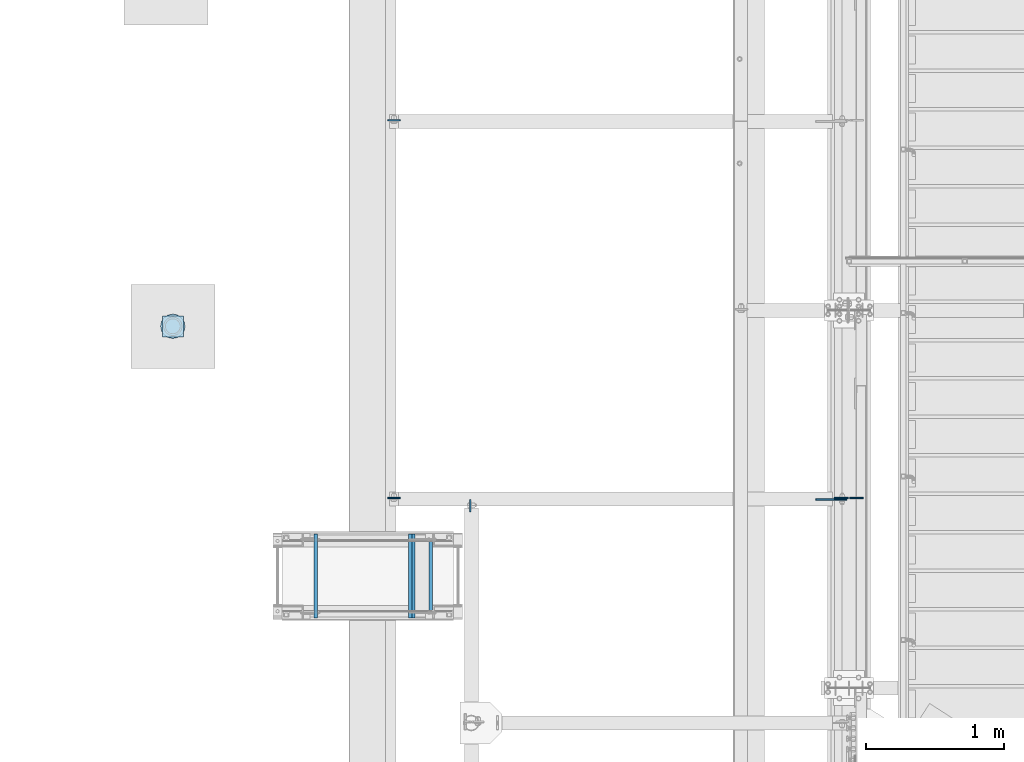
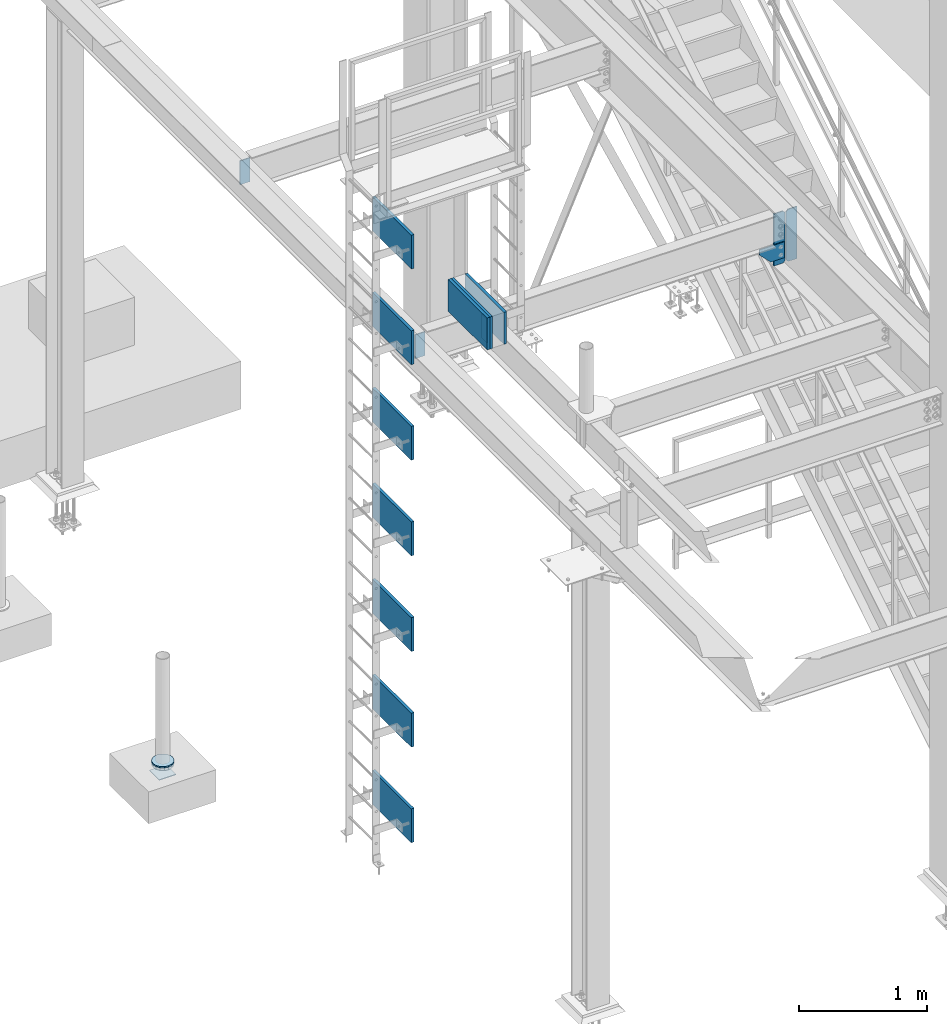
# One storey, part 3022 of 3843: 19 plates, 15 elements without a shape of their own.
"""IFC2X3 building model written with IfcOpenShell, lengths in millimetres."""

from ifc_helpers import new_model, si_unit, frame, origin_with_axes, place, context, subcontext, project, spatial, faceted_brep, material, type_object, element, aggregate, save


model = new_model("IFC2X3")

# Units and contexts
model_context = context("Model", 3, precision=1e-05, world=origin_with_axes())
body_context = subcontext(model_context, "Body", "Model", "MODEL_VIEW")
ifc_project = project(units=[si_unit("LENGTHUNIT", "METRE", prefix="MILLI"), si_unit("AREAUNIT", "SQUARE_METRE"), si_unit("VOLUMEUNIT", "CUBIC_METRE"), si_unit("MASSUNIT", "GRAM", prefix="KILO"), si_unit("TIMEUNIT", "SECOND"), si_unit("PLANEANGLEUNIT", "RADIAN"), si_unit("SOLIDANGLEUNIT", "STERADIAN"), si_unit("THERMODYNAMICTEMPERATUREUNIT", "DEGREE_CELSIUS"), si_unit("LUMINOUSINTENSITYUNIT", "LUMEN")], contexts=[model_context])

# Site, building, storey
site_placement = place(None, origin_with_axes())
site = spatial("IfcSite", under=ifc_project, at=site_placement, CompositionType="ELEMENT")
building_placement = place(site_placement, origin_with_axes())
building = spatial("IfcBuilding", under=site, at=building_placement, Name="Undefined", CompositionType="ELEMENT")
storey_placement = place(building_placement, origin_with_axes())
storey = spatial("IfcBuildingStorey", under=building, at=storey_placement, Name="Undefined", CompositionType="ELEMENT", Elevation=0.0)

# Assembly, plate
assembly_1_placement = place(storey_placement, origin_with_axes())
assembly_1 = element("IfcElementAssembly", 1, at=assembly_1_placement, inside=storey, Name="PLATE", AssemblyPlace="NOTDEFINED", PredefinedType="RIGID_FRAME")
ifc_material_1 = material(Name="STEEL/A572-50")
plate_type_1 = type_object("IfcPlateType", PredefinedType="NOTDEFINED")
plate_1_placement = place(assembly_1_placement, frame((31589.1001493349, 29690.6733759337, 30375.225), z_axis=(1.0, 0.0, 0.0), x_axis=(0.0, -1.0, 0.0)))
plate_1 = element("IfcPlate", 2, at=plate_1_placement, type_object=plate_type_1, material=ifc_material_1, Name="PLATE", context=body_context, shape_type="Brep", body=[
    faceted_brep([(0.0, -3.17499999999927, 0.0), (0.0, -3.17499999999927, 152.326975998483), (0.0, 3.17499999999927, 152.326975998483), (0.0, 3.17499999999927, 0.0), (152.326976003387, -3.17499999999927, 152.326975998483), (152.326976003387, 3.17499999999927, 152.326975998483), (152.326976003387, -3.17499999999927, 0.0), (152.326976003387, 3.17499999999927, 0.0)], [[[0, 1, 2, 3]], [[1, 4, 5, 2]], [[4, 6, 7, 5]], [[6, 0, 3, 7]], [[5, 7, 3, 2]], [[6, 4, 1, 0]]]),
])

assembly_2_placement = place(storey_placement, origin_with_axes())
assembly_2 = element("IfcElementAssembly", 3, at=assembly_2_placement, inside=storey, Name="PIPE_BOLLARD", AssemblyPlace="NOTDEFINED", PredefinedType="RIGID_FRAME")
plate_type_2 = type_object("IfcPlateType", PredefinedType="NOTDEFINED")
plate_2_placement = place(assembly_2_placement, frame((31576.3636373341, 29703.4098879337, 30486.35), z_axis=(1.0, 0.0, 0.0), x_axis=(0.0, -1.0, 0.0)))
plate_2 = element("IfcPlate", 4, at=plate_2_placement, type_object=plate_type_2, material=ifc_material_1, Name="PLATE", context=body_context, shape_type="Brep", body=[
    faceted_brep([(0.0, -6.34999999999854, 88.9000015258789), (6.76710967589679, -6.34999999999854, 122.920556195299), (6.76710967589679, 6.34999999999854, 122.920556195299), (0.0, 6.34999999999854, 88.9000015258789), (26.0382075994357, -6.34999999999854, 151.761792400561), (26.0382075994357, 6.34999999999854, 151.761792400561), (54.8794438046934, -6.34999999999854, 171.032890324102), (54.8794438046934, 6.34999999999854, 171.032890324102), (88.8999984741095, -6.34999999999854, 177.800000000003), (88.8999984741095, 6.34999999999854, 177.800000000003), (122.920556195295, -6.34999999999854, 171.032890324102), (122.920556195295, 6.34999999999854, 171.032890324102), (151.761792400553, -6.34999999999854, 151.761792400561), (151.761792400553, 6.34999999999854, 151.761792400561), (171.032890324092, -6.34999999999854, 122.920556195299), (171.032890324092, 6.34999999999854, 122.920556195299), (177.799999999988, -6.34999999999854, 88.9000015258789), (177.799999999988, 6.34999999999854, 88.9000015258789), (171.032890324091, -6.34999999999854, 54.8794438046898), (171.032890324091, 6.34999999999854, 54.8794438046898), (151.761792400553, -6.34999999999854, 26.0382075994421), (151.761792400553, 6.34999999999854, 26.0382075994421), (122.920556195295, -6.34999999999854, 6.76710967590043), (122.920556195295, 6.34999999999854, 6.76710967590043), (88.9000015258789, -6.34999999999854, 0.0), (88.9000015258789, 6.34999999999854, 0.0), (54.8794438046934, -6.34999999999854, 6.76710967590043), (54.8794438046934, 6.34999999999854, 6.76710967590043), (26.0382075994357, -6.34999999999854, 26.0382075994421), (26.0382075994357, 6.34999999999854, 26.0382075994421), (6.76710967589679, -6.34999999999854, 54.8794438046898), (6.76710967589679, 6.34999999999854, 54.8794438046898)], [[[0, 1, 2, 3]], [[1, 4, 5, 2]], [[4, 6, 7, 5]], [[6, 8, 9, 7]], [[8, 10, 11, 9]], [[10, 12, 13, 11]], [[12, 14, 15, 13]], [[14, 16, 17, 15]], [[16, 18, 19, 17]], [[18, 20, 21, 19]], [[20, 22, 23, 21]], [[22, 24, 25, 23]], [[24, 26, 27, 25]], [[26, 28, 29, 27]], [[28, 30, 31, 29]], [[30, 0, 3, 31]], [[5, 7, 9, 11, 13, 15, 17, 19, 21, 23, 25, 27, 29, 31, 3, 2]], [[30, 28, 26, 24, 22, 20, 18, 16, 14, 12, 10, 8, 6, 4, 1, 0]]]),
])
aggregate(assembly_2, [plate_2])

# Plate
plate_type_3 = type_object("IfcPlateType", PredefinedType="NOTDEFINED")
plate_3_placement = place(assembly_1_placement, frame((31576.3636373341, 29703.4098879337, 30467.3), z_axis=(1.0, 0.0, 0.0), x_axis=(0.0, -1.0, 0.0)))
plate_3 = element("IfcPlate", 5, at=plate_3_placement, type_object=plate_type_3, material=ifc_material_1, Name="PLATE", context=body_context, shape_type="Brep", body=[
    faceted_brep([(0.0, -12.7000000000007, 88.9000015258789), (6.76710967589679, -12.7000000000007, 122.920556195299), (6.76710967589679, 12.7000000000007, 122.920556195299), (0.0, 12.7000000000007, 88.9000015258789), (26.0382075994357, -12.7000000000007, 151.761792400561), (26.0382075994357, 12.7000000000007, 151.761792400561), (54.8794438046934, -12.7000000000007, 171.032890324102), (54.8794438046934, 12.7000000000007, 171.032890324102), (88.8999984741095, -12.7000000000007, 177.800000000003), (88.8999984741095, 12.7000000000007, 177.800000000003), (122.920556195295, -12.7000000000007, 171.032890324102), (122.920556195295, 12.7000000000007, 171.032890324102), (151.761792400553, -12.7000000000007, 151.761792400561), (151.761792400553, 12.7000000000007, 151.761792400561), (171.032890324092, -12.7000000000007, 122.920556195299), (171.032890324092, 12.7000000000007, 122.920556195299), (177.799999999988, -12.7000000000007, 88.9000015258789), (177.799999999988, 12.7000000000007, 88.9000015258789), (171.032890324091, -12.7000000000007, 54.8794438046898), (171.032890324091, 12.7000000000007, 54.8794438046898), (151.761792400553, -12.7000000000007, 26.0382075994421), (151.761792400553, 12.7000000000007, 26.0382075994421), (122.920556195295, -12.7000000000007, 6.76710967590043), (122.920556195295, 12.7000000000007, 6.76710967590043), (88.9000015258789, -12.7000000000007, 0.0), (88.9000015258789, 12.7000000000007, 0.0), (54.8794438046934, -12.7000000000007, 6.76710967590043), (54.8794438046934, 12.7000000000007, 6.76710967590043), (26.0382075994357, -12.7000000000007, 26.0382075994421), (26.0382075994357, 12.7000000000007, 26.0382075994421), (6.76710967589679, -12.7000000000007, 54.8794438046898), (6.76710967589679, 12.7000000000007, 54.8794438046898)], [[[0, 1, 2, 3]], [[1, 4, 5, 2]], [[4, 6, 7, 5]], [[6, 8, 9, 7]], [[8, 10, 11, 9]], [[10, 12, 13, 11]], [[12, 14, 15, 13]], [[14, 16, 17, 15]], [[16, 18, 19, 17]], [[18, 20, 21, 19]], [[20, 22, 23, 21]], [[22, 24, 25, 23]], [[24, 26, 27, 25]], [[26, 28, 29, 27]], [[28, 30, 31, 29]], [[30, 0, 3, 31]], [[5, 7, 9, 11, 13, 15, 17, 19, 21, 23, 25, 27, 29, 31, 3, 2]], [[30, 28, 26, 24, 22, 20, 18, 16, 14, 12, 10, 8, 6, 4, 1, 0]]]),
])

aggregate(assembly_1, [plate_1, plate_3])

# Assembly, plate
assembly_3_placement = place(storey_placement, origin_with_axes())
assembly_3 = element("IfcElementAssembly", 6, at=assembly_3_placement, inside=storey, Name="PLYWOOD", AssemblyPlace="NOTDEFINED", PredefinedType="NOTDEFINED")
ifc_material_2 = material(Name="TIMBER/PLYWOOD")
plate_type_4 = type_object("IfcPlateType", PredefinedType="NOTDEFINED")
plate_4_placement = place(assembly_3_placement, frame((33400.5253801807, 27800.3002775066, 35407.6158807054), z_axis=(1.72100001509535e-06, 0.0, -0.999999999998519), x_axis=(-0.999999999998519, 0.0, -1.72100001467194e-06)))
plate_4 = element("IfcPlate", 7, at=plate_4_placement, type_object=plate_type_4, material=ifc_material_2, Name="PLYWOOD", context=body_context, shape_type="Brep", body=[
    faceted_brep([(0.0, -304.799999999999, 0.0), (-3.17594676744193e-05, -304.799999999999, 305.395313003275), (-3.17594676744193e-05, 304.799999999999, 305.395313003275), (0.0, 304.799999999999, 0.0), (25.3999682407812, -304.799999999999, 305.395313003195), (25.3999682407812, 304.799999999999, 305.395313003195), (25.4000000002561, -304.799999999999, -8.00355337560177e-11), (25.4000000002561, 304.799999999999, -8.00355337560177e-11)], [[[0, 1, 2, 3]], [[1, 4, 5, 2]], [[4, 6, 7, 5]], [[6, 0, 3, 7]], [[5, 7, 3, 2]], [[6, 4, 1, 0]]]),
])
aggregate(assembly_3, [plate_4])

assembly_4_placement = place(storey_placement, origin_with_axes())
assembly_4 = element("IfcElementAssembly", 8, at=assembly_4_placement, inside=storey, Name="PLYWOOD", AssemblyPlace="NOTDEFINED", PredefinedType="NOTDEFINED")
plate_5_placement = place(assembly_4_placement, frame((33425.9253801807, 27800.3002775066, 35407.6158807054), z_axis=(1.72100001509535e-06, 0.0, -0.999999999998519), x_axis=(-0.999999999998519, 0.0, -1.72100001467194e-06)))
plate_5 = element("IfcPlate", 9, at=plate_5_placement, type_object=plate_type_4, material=ifc_material_2, Name="PLYWOOD", context=body_context, shape_type="Brep", body=[
    faceted_brep([(0.0, -304.799999999999, 0.0), (-3.17594676744193e-05, -304.799999999999, 305.395313003275), (-3.17594676744193e-05, 304.799999999999, 305.395313003275), (0.0, 304.799999999999, 0.0), (25.3999682407812, -304.799999999999, 305.395313003195), (25.3999682407812, 304.799999999999, 305.395313003195), (25.4000000002561, -304.799999999999, -8.00355337560177e-11), (25.4000000002561, 304.799999999999, -8.00355337560177e-11)], [[[0, 1, 2, 3]], [[1, 4, 5, 2]], [[4, 6, 7, 5]], [[6, 0, 3, 7]], [[5, 7, 3, 2]], [[6, 4, 1, 0]]]),
])
aggregate(assembly_4, [plate_5])

assembly_5_placement = place(storey_placement, origin_with_axes())
assembly_5 = element("IfcElementAssembly", 10, at=assembly_5_placement, inside=storey, Name="PLYWOOD", AssemblyPlace="NOTDEFINED", PredefinedType="NOTDEFINED")
plate_6_placement = place(assembly_5_placement, frame((33552.9253801807, 27800.3002775066, 35407.6158807054), z_axis=(1.72100001509535e-06, 0.0, -0.999999999998519), x_axis=(-0.999999999998519, 0.0, -1.72100001467194e-06)))
plate_6 = element("IfcPlate", 11, at=plate_6_placement, type_object=plate_type_4, material=ifc_material_2, Name="PLYWOOD", context=body_context, shape_type="Brep", body=[
    faceted_brep([(0.0, -304.799999999999, 0.0), (-3.17594676744193e-05, -304.799999999999, 305.395313003275), (-3.17594676744193e-05, 304.799999999999, 305.395313003275), (0.0, 304.799999999999, 0.0), (25.3999682407812, -304.799999999999, 305.395313003195), (25.3999682407812, 304.799999999999, 305.395313003195), (25.4000000002561, -304.799999999999, -8.00355337560177e-11), (25.4000000002561, 304.799999999999, -8.00355337560177e-11)], [[[0, 1, 2, 3]], [[1, 4, 5, 2]], [[4, 6, 7, 5]], [[6, 0, 3, 7]], [[5, 7, 3, 2]], [[6, 4, 1, 0]]]),
])
aggregate(assembly_5, [plate_6])

assembly_6_placement = place(storey_placement, origin_with_axes())
assembly_6 = element("IfcElementAssembly", 12, at=assembly_6_placement, inside=storey, Name="PLYWOOD", AssemblyPlace="NOTDEFINED", PredefinedType="NOTDEFINED")
plate_7_placement = place(assembly_6_placement, frame((32714.7253801807, 27800.3002775066, 36439.0940057054), z_axis=(1.72100001509535e-06, 0.0, -0.999999999998519), x_axis=(-0.999999999998519, 0.0, -1.72100001467194e-06)))
plate_7 = element("IfcPlate", 13, at=plate_7_placement, type_object=plate_type_4, material=ifc_material_2, Name="PLYWOOD", context=body_context, shape_type="Brep", body=[
    faceted_brep([(0.0, -304.799999999999, 0.0), (0.0, -304.800000000003, 323.849999999999), (0.0, 304.800000000003, 323.849999999999), (0.0, 304.799999999999, 0.0), (25.3999999999942, -304.800000000003, 323.849999999999), (25.3999999999942, 304.800000000003, 323.849999999999), (25.4000000002561, -304.799999999999, -8.00355337560177e-11), (25.4000000002561, 304.799999999999, -8.00355337560177e-11)], [[[0, 1, 2, 3]], [[1, 4, 5, 2]], [[4, 6, 7, 5]], [[6, 0, 3, 7]], [[5, 7, 3, 2]], [[6, 4, 1, 0]]]),
])
aggregate(assembly_6, [plate_7])

assembly_7_placement = place(storey_placement, origin_with_axes())
assembly_7 = element("IfcElementAssembly", 14, at=assembly_7_placement, inside=storey, Name="PLYWOOD", AssemblyPlace="NOTDEFINED", PredefinedType="NOTDEFINED")
plate_8_placement = place(assembly_7_placement, frame((32714.7253801807, 27800.3002775066, 35524.6940057054), z_axis=(1.72100001509535e-06, 0.0, -0.999999999998519), x_axis=(-0.999999999998519, 0.0, -1.72100001467194e-06)))
plate_8 = element("IfcPlate", 15, at=plate_8_placement, type_object=plate_type_4, material=ifc_material_2, Name="PLYWOOD", context=body_context, shape_type="Brep", body=[
    faceted_brep([(0.0, -304.799999999999, 0.0), (0.0, -304.800000000003, 323.849999999999), (0.0, 304.800000000003, 323.849999999999), (0.0, 304.799999999999, 0.0), (25.3999999999942, -304.800000000003, 323.849999999999), (25.3999999999942, 304.800000000003, 323.849999999999), (25.4000000002561, -304.799999999999, -8.00355337560177e-11), (25.4000000002561, 304.799999999999, -8.00355337560177e-11)], [[[0, 1, 2, 3]], [[1, 4, 5, 2]], [[4, 6, 7, 5]], [[6, 0, 3, 7]], [[5, 7, 3, 2]], [[6, 4, 1, 0]]]),
])
aggregate(assembly_7, [plate_8])

assembly_8_placement = place(storey_placement, origin_with_axes())
assembly_8 = element("IfcElementAssembly", 16, at=assembly_8_placement, inside=storey, Name="PLYWOOD", AssemblyPlace="NOTDEFINED", PredefinedType="NOTDEFINED")
plate_9_placement = place(assembly_8_placement, frame((32714.7253801807, 27800.3002775066, 34610.2940057054), z_axis=(1.72100001509535e-06, 0.0, -0.999999999998519), x_axis=(-0.999999999998519, 0.0, -1.72100001467194e-06)))
plate_9 = element("IfcPlate", 17, at=plate_9_placement, type_object=plate_type_4, material=ifc_material_2, Name="PLYWOOD", context=body_context, shape_type="Brep", body=[
    faceted_brep([(0.0, -304.799999999999, 0.0), (0.0, -304.800000000003, 323.849999999999), (0.0, 304.800000000003, 323.849999999999), (0.0, 304.799999999999, 0.0), (25.3999999999942, -304.800000000003, 323.849999999999), (25.3999999999942, 304.800000000003, 323.849999999999), (25.4000000002561, -304.799999999999, -8.00355337560177e-11), (25.4000000002561, 304.799999999999, -8.00355337560177e-11)], [[[0, 1, 2, 3]], [[1, 4, 5, 2]], [[4, 6, 7, 5]], [[6, 0, 3, 7]], [[5, 7, 3, 2]], [[6, 4, 1, 0]]]),
])
aggregate(assembly_8, [plate_9])

assembly_9_placement = place(storey_placement, origin_with_axes())
assembly_9 = element("IfcElementAssembly", 18, at=assembly_9_placement, inside=storey, Name="PLYWOOD", AssemblyPlace="NOTDEFINED", PredefinedType="NOTDEFINED")
plate_10_placement = place(assembly_9_placement, frame((32714.7253801807, 27800.3002775066, 33695.8940057054), z_axis=(1.72100001509535e-06, 0.0, -0.999999999998519), x_axis=(-0.999999999998519, 0.0, -1.72100001467194e-06)))
plate_10 = element("IfcPlate", 19, at=plate_10_placement, type_object=plate_type_4, material=ifc_material_2, Name="PLYWOOD", context=body_context, shape_type="Brep", body=[
    faceted_brep([(0.0, -304.799999999999, 0.0), (0.0, -304.800000000003, 323.849999999999), (0.0, 304.800000000003, 323.849999999999), (0.0, 304.799999999999, 0.0), (25.3999999999942, -304.800000000003, 323.849999999999), (25.3999999999942, 304.800000000003, 323.849999999999), (25.4000000002561, -304.799999999999, -8.00355337560177e-11), (25.4000000002561, 304.799999999999, -8.00355337560177e-11)], [[[0, 1, 2, 3]], [[1, 4, 5, 2]], [[4, 6, 7, 5]], [[6, 0, 3, 7]], [[5, 7, 3, 2]], [[6, 4, 1, 0]]]),
])
aggregate(assembly_9, [plate_10])

assembly_10_placement = place(storey_placement, origin_with_axes())
assembly_10 = element("IfcElementAssembly", 20, at=assembly_10_placement, inside=storey, Name="PLYWOOD", AssemblyPlace="NOTDEFINED", PredefinedType="NOTDEFINED")
plate_11_placement = place(assembly_10_placement, frame((32714.7253801807, 27800.3002775066, 32781.4940057054), z_axis=(1.72100001509535e-06, 0.0, -0.999999999998519), x_axis=(-0.999999999998519, 0.0, -1.72100001467194e-06)))
plate_11 = element("IfcPlate", 21, at=plate_11_placement, type_object=plate_type_4, material=ifc_material_2, Name="PLYWOOD", context=body_context, shape_type="Brep", body=[
    faceted_brep([(0.0, -304.799999999999, 0.0), (0.0, -304.800000000003, 323.849999999999), (0.0, 304.800000000003, 323.849999999999), (0.0, 304.799999999999, 0.0), (25.3999999999942, -304.800000000003, 323.849999999999), (25.3999999999942, 304.800000000003, 323.849999999999), (25.4000000002561, -304.799999999999, -8.00355337560177e-11), (25.4000000002561, 304.799999999999, -8.00355337560177e-11)], [[[0, 1, 2, 3]], [[1, 4, 5, 2]], [[4, 6, 7, 5]], [[6, 0, 3, 7]], [[5, 7, 3, 2]], [[6, 4, 1, 0]]]),
])
aggregate(assembly_10, [plate_11])

assembly_11_placement = place(storey_placement, origin_with_axes())
assembly_11 = element("IfcElementAssembly", 22, at=assembly_11_placement, inside=storey, Name="PLYWOOD", AssemblyPlace="NOTDEFINED", PredefinedType="NOTDEFINED")
plate_12_placement = place(assembly_11_placement, frame((32714.7253801807, 27800.3002775066, 31867.0940057054), z_axis=(1.72100001509535e-06, 0.0, -0.999999999998519), x_axis=(-0.999999999998519, 0.0, -1.72100001467194e-06)))
plate_12 = element("IfcPlate", 23, at=plate_12_placement, type_object=plate_type_4, material=ifc_material_2, Name="PLYWOOD", context=body_context, shape_type="Brep", body=[
    faceted_brep([(0.0, -304.799999999999, 0.0), (0.0, -304.800000000003, 323.849999999999), (0.0, 304.800000000003, 323.849999999999), (0.0, 304.799999999999, 0.0), (25.3999999999942, -304.800000000003, 323.849999999999), (25.3999999999942, 304.800000000003, 323.849999999999), (25.4000000002561, -304.799999999999, -8.00355337560177e-11), (25.4000000002561, 304.799999999999, -8.00355337560177e-11)], [[[0, 1, 2, 3]], [[1, 4, 5, 2]], [[4, 6, 7, 5]], [[6, 0, 3, 7]], [[5, 7, 3, 2]], [[6, 4, 1, 0]]]),
])
aggregate(assembly_11, [plate_12])

assembly_12_placement = place(storey_placement, origin_with_axes())
assembly_12 = element("IfcElementAssembly", 24, at=assembly_12_placement, inside=storey, Name="PLYWOOD", AssemblyPlace="NOTDEFINED", PredefinedType="NOTDEFINED")
plate_13_placement = place(assembly_12_placement, frame((32714.7253801807, 27800.3002775066, 30952.6940057054), z_axis=(1.72100001509535e-06, 0.0, -0.999999999998519), x_axis=(-0.999999999998519, 0.0, -1.72100001467194e-06)))
plate_13 = element("IfcPlate", 25, at=plate_13_placement, type_object=plate_type_4, material=ifc_material_2, Name="PLYWOOD", context=body_context, shape_type="Brep", body=[
    faceted_brep([(0.0, -304.799999999999, 0.0), (0.0, -304.800000000003, 323.849999999999), (0.0, 304.800000000003, 323.849999999999), (0.0, 304.799999999999, 0.0), (25.3999999999942, -304.800000000003, 323.849999999999), (25.3999999999942, 304.800000000003, 323.849999999999), (25.4000000002561, -304.799999999999, -8.00355337560177e-11), (25.4000000002561, 304.799999999999, -8.00355337560177e-11)], [[[0, 1, 2, 3]], [[1, 4, 5, 2]], [[4, 6, 7, 5]], [[6, 0, 3, 7]], [[5, 7, 3, 2]], [[6, 4, 1, 0]]]),
])
aggregate(assembly_12, [plate_13])

assembly_13_placement = place(storey_placement, origin_with_axes())
assembly_13 = element("IfcElementAssembly", 26, at=assembly_13_placement, inside=storey, Name="BEAM", AssemblyPlace="NOTDEFINED", PredefinedType="RIGID_FRAME")
plate_type_5 = type_object("IfcPlateType", PredefinedType="NOTDEFINED")
plate_14_placement = place(assembly_13_placement, frame((33824.8625, 28355.925, 34772.6), z_axis=(0.0, -1.0, 0.0), x_axis=(0.0, 0.0, -1.0)))
plate_14 = element("IfcPlate", 27, at=plate_14_placement, type_object=plate_type_5, material=ifc_material_1, Name="PLATE", context=body_context, shape_type="Brep", body=[
    faceted_brep([(0.0, -4.76249999999709, 0.0), (0.0, -4.76249999999709, 88.9000015258789), (0.0, 4.76249999999709, 88.9000015258789), (0.0, 4.76249999999709, 0.0), (228.600006102781, -4.7625000004191, 88.9000015257589), (228.600006102781, 4.76249999954598, 88.9000015257443), (228.600006103079, -4.7625000004482, 7.27595761418343e-12), (228.600006103079, 4.76249999954598, -7.27595761418343e-12)], [[[0, 1, 2, 3]], [[1, 4, 5, 2]], [[4, 6, 7, 5]], [[6, 0, 3, 7]], [[5, 7, 3, 2]], [[6, 4, 1, 0]]]),
])

# Assembly, plates
assembly_14_placement = place(storey_placement, origin_with_axes())
assembly_14 = element("IfcElementAssembly", 28, at=assembly_14_placement, inside=storey, Name="BEAM", AssemblyPlace="NOTDEFINED", PredefinedType="RIGID_FRAME")
plate_15_placement = place(assembly_14_placement, frame((33226.375, 28367.0375, 34772.6), z_axis=(1.0, 0.0, 0.0), x_axis=(0.0, 0.0, -1.0)))
plate_15 = element("IfcPlate", 29, at=plate_15_placement, type_object=plate_type_5, material=ifc_material_1, Name="PLATE", context=body_context, shape_type="Brep", body=[
    faceted_brep([(0.0, -4.76249999999709, 0.0), (0.0, -4.76249999999709, 88.9000015258789), (0.0, 4.76249999999709, 88.9000015258789), (0.0, 4.76249999999709, 0.0), (228.600006102781, -4.7625000004191, 88.9000015257589), (228.600006102781, 4.76249999954598, 88.9000015257443), (228.600006103079, -4.7625000004482, 7.27595761418343e-12), (228.600006103079, 4.76249999954598, -7.27595761418343e-12)], [[[0, 1, 2, 3]], [[1, 4, 5, 2]], [[4, 6, 7, 5]], [[6, 0, 3, 7]], [[5, 7, 3, 2]], [[6, 4, 1, 0]]]),
])
plate_16_placement = place(assembly_14_placement, frame((33226.375, 31110.2375, 34772.6), z_axis=(1.0, 0.0, 0.0), x_axis=(0.0, 0.0, -1.0)))
plate_16 = element("IfcPlate", 30, at=plate_16_placement, type_object=plate_type_5, material=ifc_material_1, Name="PLATE", context=body_context, shape_type="Brep", body=[
    faceted_brep([(0.0, -4.76249999999709, 0.0), (0.0, -4.76249999999709, 88.9000015258789), (0.0, 4.76249999999709, 88.9000015258789), (0.0, 4.76249999999709, 0.0), (228.600006102781, -4.7625000004191, 88.9000015257589), (228.600006102781, 4.76249999954598, 88.9000015257443), (228.600006103079, -4.7625000004482, 7.27595761418343e-12), (228.600006103079, 4.76249999954598, -7.27595761418343e-12)], [[[0, 1, 2, 3]], [[1, 4, 5, 2]], [[4, 6, 7, 5]], [[6, 0, 3, 7]], [[5, 7, 3, 2]], [[6, 4, 1, 0]]]),
])
aggregate(assembly_14, [plate_15, plate_16])

# Assembly, plate
assembly_15_placement = place(storey_placement, origin_with_axes())
assembly_15 = element("IfcElementAssembly", 31, at=assembly_15_placement, inside=storey, Name="BEAM", AssemblyPlace="NOTDEFINED", PredefinedType="RIGID_FRAME")
plate_type_6 = type_object("IfcPlateType", PredefinedType="NOTDEFINED")
plate_17_placement = place(assembly_15_placement, frame((36571.2375, 28367.0379999161, 34294.7625), z_axis=(0.0, 0.0, 1.0), x_axis=(-1.0, 0.0, 0.0)))
plate_17 = element("IfcPlate", 32, at=plate_17_placement, type_object=plate_type_6, material=ifc_material_1, Name="PLATE", context=body_context, shape_type="Brep", body=[
    faceted_brep([(0.0, -4.76249999999709, 19.0499992370605), (0.0, -4.76250000000073, 479.425000762938), (0.0, 4.76250000000073, 479.425000762938), (0.0, 4.76249999999709, 19.0499992370605), (19.0499992370605, -4.76250000000073, 498.474999999999), (19.0499992370605, 4.76250000000073, 498.474999999999), (101.600000000006, -4.76250000000073, 498.474999999999), (101.600000000006, 4.76250000000073, 498.474999999999), (101.600000000006, -4.76250000000073, 0.0), (101.600000000006, 4.76250000000073, 0.0), (19.0499992370605, -4.76249999999709, 0.0), (19.0499992370605, 4.76249999999709, 0.0)], [[[0, 1, 2, 3]], [[1, 4, 5, 2]], [[4, 6, 7, 5]], [[6, 8, 9, 7]], [[8, 10, 11, 9]], [[10, 0, 3, 11]], [[5, 7, 9, 11, 3, 2]], [[10, 8, 6, 4, 1, 0]]]),
])

# Plate
plate_type_7 = type_object("IfcPlateType", PredefinedType="NOTDEFINED")
plate_18_placement = place(assembly_13_placement, frame((36335.3289400347, 28357.5129999161, 34502.725), z_axis=(0.0, 0.0, -1.0), x_axis=(1.0, 0.0, 0.0)))
plate_18 = element("IfcPlate", 33, at=plate_18_placement, type_object=plate_type_7, material=ifc_material_1, Name="PLATE", context=body_context, shape_type="Brep", body=[
    faceted_brep([(0.0, -4.76249999999709, 0.0), (0.0, -4.76250000000073, 50.7893728663621), (0.0, 4.76250000000073, 50.7893728663621), (0.0, 4.76249999999709, 0.0), (101.599998474121, -4.76250000000073, 152.389371340483), (101.599998474121, 4.76250000000073, 152.389371340483), (223.208559965315, -4.76250000000073, 152.389371340483), (223.208559965315, 4.76250000000073, 152.389371340483), (223.208559965315, -4.76250000000073, 5.82076609134674e-11), (223.208559965315, 4.76250000000073, 5.82076609134674e-11)], [[[0, 1, 2, 3]], [[1, 4, 5, 2]], [[4, 6, 7, 5]], [[6, 8, 9, 7]], [[8, 0, 3, 9]], [[5, 7, 9, 3, 2]], [[8, 6, 4, 1, 0]]]),
])

aggregate(assembly_13, [plate_18, plate_14])

plate_type_8 = type_object("IfcPlateType", PredefinedType="NOTDEFINED")
plate_19_placement = place(assembly_15_placement, frame((36580.7625, 28367.0379999161, 34294.7625), z_axis=(0.0, 0.0, 1.0), x_axis=(1.0, 0.0, 0.0)))
plate_19 = element("IfcPlate", 34, at=plate_19_placement, type_object=plate_type_8, material=ifc_material_1, Name="PLATE", context=body_context, shape_type="Brep", body=[
    faceted_brep([(0.0, -4.76249999999709, 19.0499992370605), (0.0, -4.76250000000073, 479.425000762938), (0.0, 4.76250000000073, 479.425000762938), (0.0, 4.76249999999709, 19.0499992370605), (19.0499992370605, -4.76250000000073, 498.474999999999), (19.0499992370605, 4.76250000000073, 498.474999999999), (100.012500000004, -4.76250000000073, 498.474999999999), (100.012500000004, 4.76250000000073, 498.474999999999), (100.012500000004, -4.76250000000073, 0.0), (100.012500000004, 4.76250000000073, 0.0), (19.0499992370605, -4.76249999999709, 0.0), (19.0499992370605, 4.76249999999709, 0.0)], [[[0, 1, 2, 3]], [[1, 4, 5, 2]], [[4, 6, 7, 5]], [[6, 8, 9, 7]], [[8, 10, 11, 9]], [[10, 0, 3, 11]], [[5, 7, 9, 11, 3, 2]], [[10, 8, 6, 4, 1, 0]]]),
])

aggregate(assembly_15, [plate_19, plate_17])

save(model, "model.ifc")
